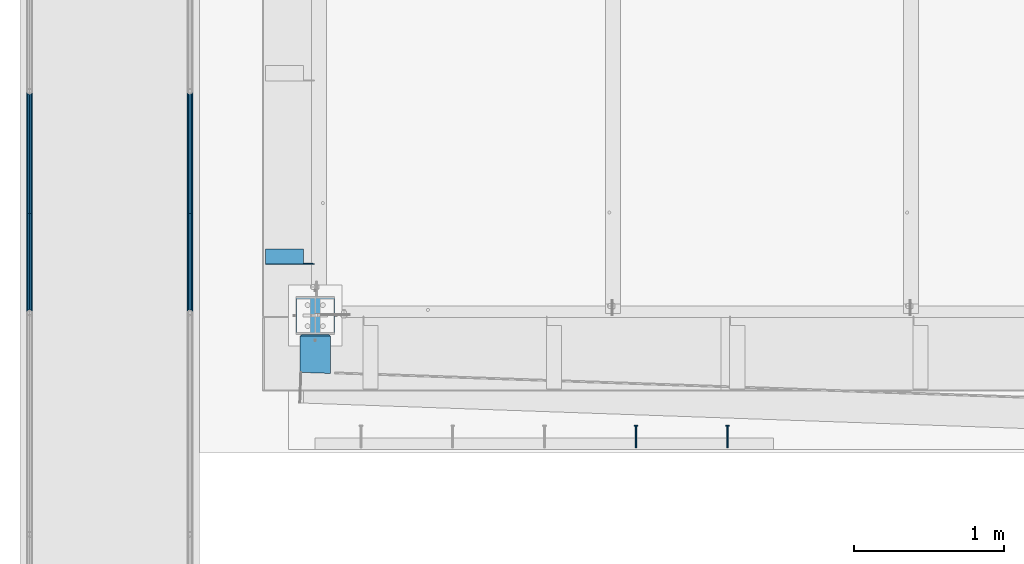
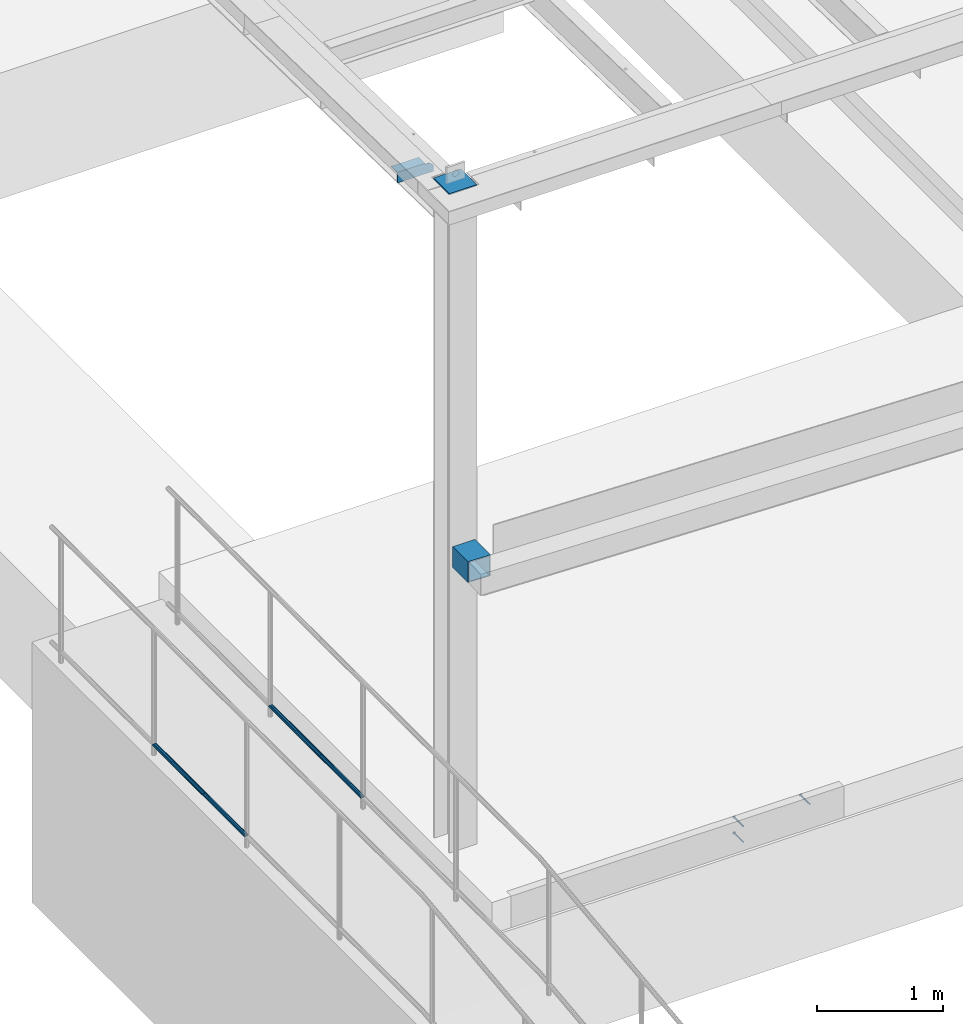
# One storey, part 1184 of 1763: 10 beams, 7 elements without a shape of their own.
"""IFC2X3 building model written with IfcOpenShell, lengths in millimetres."""

from ifc_helpers import new_model, si_unit, frame, origin_with_axes, place, context, subcontext, project, spatial, faceted_brep, material, type_object, element, aggregate, save


model = new_model("IFC2X3")

# Units and contexts
model_context = context("Model", 3, precision=1e-05, world=origin_with_axes())
body_context = subcontext(model_context, "Body", "Model", "MODEL_VIEW")
ifc_project = project(units=[si_unit("LENGTHUNIT", "METRE", prefix="MILLI"), si_unit("AREAUNIT", "SQUARE_METRE"), si_unit("VOLUMEUNIT", "CUBIC_METRE"), si_unit("MASSUNIT", "GRAM", prefix="KILO"), si_unit("TIMEUNIT", "SECOND"), si_unit("PLANEANGLEUNIT", "RADIAN"), si_unit("SOLIDANGLEUNIT", "STERADIAN"), si_unit("THERMODYNAMICTEMPERATUREUNIT", "DEGREE_CELSIUS"), si_unit("LUMINOUSINTENSITYUNIT", "LUMEN")], contexts=[model_context])

# Site, building, storey
site_placement = place(None, origin_with_axes())
site = spatial("IfcSite", under=ifc_project, at=site_placement, CompositionType="ELEMENT")
building_placement = place(site_placement, origin_with_axes())
building = spatial("IfcBuilding", under=site, at=building_placement, Name="Undefined", CompositionType="ELEMENT")
storey_placement = place(building_placement, origin_with_axes())
storey = spatial("IfcBuildingStorey", under=building, at=storey_placement, Name="Undefined", CompositionType="ELEMENT", Elevation=0.0)

# Assembly, beam
assembly_1_placement = place(storey_placement, origin_with_axes())
assembly_1 = element("IfcElementAssembly", 1, at=assembly_1_placement, inside=storey, Name="GUARDRAIL", AssemblyPlace="NOTDEFINED", PredefinedType="RIGID_FRAME")
ifc_material_1 = material(Name="STEEL/A513")
beam_type_1 = type_object("IfcBeamType", PredefinedType="NOTDEFINED")
beam_1_placement = place(assembly_1_placement, frame((-97200.6527017878, 9975.70609643643, 6031.68877066277), z_axis=(0.0, -4.62400000105845e-06, 0.999999999989309), x_axis=(0.0, 0.999999999989309, 4.62400000047487e-06)))
beam_1 = element("IfcBeam", 2, at=beam_1_placement, type_object=beam_type_1, material=ifc_material_1, Name="GUARDRAIL", context=body_context, shape_type="Brep", body=[
    faceted_brep([(796.23942056013, -9.52499999999418, 16.4977839422581), (796.239395102903, -9.52499999999418, 11.4667123801219), (795.745975983124, -7.68349999999919, 13.3082123801214), (793.687198780424, 0.0, 15.3670000001657), (793.687217416407, 0.0, 19.0500000001639), (795.745975983124, 7.68349999999919, 13.3082123801214), (796.239395102903, 9.52499999999418, 11.4667123801219), (796.23942056013, 9.52499999999418, 16.4977839422581), (812.737175030752, 19.0500000000029, 1.72803993336856e-10), (803.21216922002, 16.4977839420899, 9.5250000001688), (803.212072827002, 16.4977839420899, -9.52499999982774), (800.022588339951, 13.3082123799541, 7.68350000016835), (802.08133708151, 15.3669999999984, 1.70075509231538e-10), (800.022510582932, 13.3082123799541, -7.6834999998282), (796.239279059755, 9.52499999999418, -11.4667123797844), (796.239253602527, 9.52499999999418, -16.4977839419216), (795.745841304017, 7.68349999999919, -13.308212379784), (793.687043266358, 0.0, -15.3669999998283), (793.687024630375, 0.0, -19.0499999998274), (796.239279059755, -9.52499999999418, -11.4667123797844), (796.239253602527, -9.52499999999418, -16.4977839419216), (795.745841304017, -7.68349999999919, -13.308212379784), (812.737121023631, -19.0500000000029, 4.44742909166962e-10), (803.212072827002, -16.4977839420899, -9.52499999982774), (803.21216922002, -16.4977839420899, 9.5250000001688), (800.022510582934, -13.3082123799541, -7.6834999998282), (802.081337081512, -15.3669999999984, 1.70075509231538e-10), (800.022588339953, -13.3082123799541, 7.68350000016835), (0.0, -16.4977839420899, -9.52500000000146), (0.0, -9.52499999999418, -16.4977839420935), (1.45519152283669e-11, 1.81898940354586e-12, -19.0499999999993), (0.0, 9.52499999999418, -16.4977839420935), (0.0, 16.4977839420899, -9.52500000000146), (0.0, 19.0500000000029, 0.0), (0.0, 16.4977839420899, 9.52500000000146), (0.0, 9.52499999999418, 16.4977839420935), (1.45519152283669e-11, 1.81898940354586e-12, 19.0499999999993), (0.0, -9.52499999999418, 16.4977839420935), (0.0, -16.4977839420899, 9.52500000000146), (0.0, -19.0500000000029, 0.0), (3.63797880709171e-12, -13.3082123799541, -7.68349999999737), (3.63797880709171e-12, -7.68349999999919, -13.3082123799522), (3.63797880709171e-12, 0.0, -15.3669999999956), (3.63797880709171e-12, 7.68349999999919, -13.3082123799522), (3.63797880709171e-12, 13.3082123799541, -7.68349999999737), (4.71409293822944e-08, 15.3669999999984, 0.0), (-1.81898940354586e-12, 13.3082123799541, 7.68349999999919), (-3.63797880709171e-12, 7.68349999999919, 13.3082123799531), (-1.81898940354586e-12, 0.0, 15.3669999999966), (-3.63797880709171e-12, -7.68349999999919, 13.3082123799531), (-1.81898940354586e-12, -13.3082123799541, 7.68349999999919), (4.71409293822944e-08, -15.3669999999984, 0.0)], [[[0, 1, 2, 3, 4]], [[4, 3, 5, 6, 7]], [[8, 9, 10]], [[7, 6, 11, 12, 13, 14, 15, 10, 9]], [[16, 17, 18, 15, 14]], [[19, 20, 18, 17, 21]], [[22, 23, 24]], [[24, 23, 20, 19, 25, 26, 27, 1, 0]], [[28, 29, 20, 23]], [[29, 30, 18, 20]], [[30, 31, 15, 18]], [[31, 32, 10, 15]], [[32, 33, 8, 10]], [[33, 34, 9, 8]], [[34, 35, 7, 9]], [[35, 36, 4, 7]], [[36, 37, 0, 4]], [[37, 38, 24, 0]], [[38, 39, 22, 24]], [[39, 28, 23, 22]], [[38, 37, 36, 35, 34, 33, 32, 31, 30, 29, 28, 39], [40, 41, 42, 43, 44, 45, 46, 47, 48, 49, 50, 51]], [[40, 51, 26, 25]], [[21, 41, 40, 25, 19]], [[42, 41, 21, 17]], [[43, 42, 17, 16]], [[44, 43, 16, 14, 13]], [[45, 44, 13, 12]], [[46, 45, 12, 11]], [[5, 47, 46, 11, 6]], [[48, 47, 5, 3]], [[49, 48, 3, 2]], [[50, 49, 2, 1, 27]], [[51, 50, 27, 26]]]),
])
aggregate(assembly_1, [beam_1])

assembly_2_placement = place(storey_placement, origin_with_axes())
assembly_2 = element("IfcElementAssembly", 3, at=assembly_2_placement, inside=storey, Name="GUARDRAIL", AssemblyPlace="NOTDEFINED", PredefinedType="RIGID_FRAME")
beam_2_placement = place(assembly_2_placement, frame((-97200.6527017878, 9313.07722717828, 6031.68570659609), z_axis=(0.0, -4.62400000105845e-06, 0.999999999989309), x_axis=(0.0, 0.999999999989309, 4.62400000047487e-06)))
beam_2 = element("IfcBeam", 4, at=beam_2_placement, type_object=beam_type_1, material=ifc_material_1, Name="GUARDRAIL", context=body_context, shape_type="Brep", body=[
    faceted_brep([(2.16604427796847, 19.0500000000029, 0.0), (11.6909420741176, 16.4977839420899, -9.52499999999509), (11.6910384671355, 16.4977839420899, 9.52499999999964), (11.6910384671355, -16.4977839420899, 9.52499999999964), (11.6909420741176, -16.4977839420899, -9.52499999999509), (2.16604427796847, -19.0500000000029, 0.0), (18.6638576916084, -9.52499999999418, 16.4977839420944), (18.6638322343806, -9.52499999999418, 11.4667123799572), (14.8806007114235, -13.3082123799541, 7.68350000000191), (12.8217742128418, -15.3669999999984, 2.72848410531878e-12), (14.8805229544032, -13.3082123799541, -7.68349999999464), (18.6637161912331, -9.52499999999418, -11.4667123799491), (18.6636907340053, -9.52499999999418, -16.4977839420862), (21.2159125137114, 0.0, -15.3669999999929), (21.2158938777284, 0.0, -19.0499999999911), (19.1571353112286, -7.68349999999919, -13.3082123799486), (19.1571353112286, 7.68349999999919, -13.3082123799486), (18.6637161912331, 9.52499999999418, -11.4667123799491), (18.6636907340053, 9.52499999999418, -16.4977839420862), (14.8805229544014, 13.3082123799541, -7.68349999999464), (12.82177421284, 15.3669999999984, 2.72848410531878e-12), (14.8806007114217, 13.3082123799541, 7.68350000000191), (18.6638322343806, 9.52499999999418, 11.4667123799572), (18.6638576916084, 9.52499999999418, 16.4977839420944), (19.1572699903372, 7.68349999999919, 13.3082123799568), (21.2160680277793, 0.0, 15.3670000000011), (21.2160866637623, 0.0, 19.0500000000002), (19.1572699903372, -7.68349999999919, 13.3082123799568), (662.628869265089, -19.0500000000029, 1.40971678774804e-10), (662.628869265085, -16.4977839420899, 9.52500000013879), (662.628869265085, -9.52499999999418, 16.4977839422299), (662.628869265083, 0.0, 19.0500000001357), (662.628869265092, -9.52499999999418, -16.4977839419489), (662.628869265091, -16.4977839420899, -9.52499999985685), (662.628869265092, 0.0, -19.0499999998556), (662.628869265092, 9.52499999999418, -16.4977839419489), (662.628869265091, 16.4977839420899, -9.52499999985685), (662.628869265089, 19.0500000000029, 1.40971678774804e-10), (662.628869265085, 16.4977839420899, 9.52500000013879), (662.628869265085, 9.52499999999418, 16.4977839422299), (662.628869265085, -7.68349999999919, 13.3082123800932), (662.628869265085, 0.0, 15.3670000001375), (662.628869265085, 7.68349999999919, 13.3082123800923), (662.628869265087, 13.3082123799541, 7.68350000013834), (662.628869265089, 15.3669999999984, 1.40971678774804e-10), (662.628869265089, 13.3082123799541, -7.6834999998573), (662.628869265091, 7.68349999999919, -13.3082123798113), (662.628869265092, 0.0, -15.3669999998565), (662.628869265091, -7.68349999999919, -13.3082123798113), (662.628869265089, -13.3082123799541, -7.6834999998573), (662.628869265089, -15.3669999999984, 1.40971678774804e-10), (662.628869265087, -13.3082123799541, 7.68350000013834)], [[[0, 1, 2]], [[3, 4, 5]], [[6, 7, 8, 9, 10, 11, 12, 4, 3]], [[13, 14, 12, 11, 15]], [[16, 17, 18, 14, 13]], [[2, 1, 18, 17, 19, 20, 21, 22, 23]], [[23, 22, 24, 25, 26]], [[26, 25, 27, 7, 6]], [[28, 29, 3, 5]], [[29, 30, 6, 3]], [[30, 31, 26, 6]], [[32, 33, 4, 12]], [[34, 32, 12, 14]], [[35, 34, 14, 18]], [[36, 35, 18, 1]], [[37, 36, 1, 0]], [[38, 37, 0, 2]], [[39, 38, 2, 23]], [[31, 39, 23, 26]], [[33, 28, 5, 4]], [[32, 34, 35, 36, 37, 38, 39, 31, 30, 29, 28, 33], [40, 41, 42, 43, 44, 45, 46, 47, 48, 49, 50, 51]], [[42, 41, 25, 24]], [[21, 43, 42, 24, 22]], [[44, 43, 21, 20]], [[45, 44, 20, 19]], [[46, 45, 19, 17, 16]], [[47, 46, 16, 13]], [[48, 47, 13, 15]], [[10, 49, 48, 15, 11]], [[50, 49, 10, 9]], [[51, 50, 9, 8]], [[40, 51, 8, 7, 27]], [[41, 40, 27, 25]]]),
])
aggregate(assembly_2, [beam_2])

assembly_3_placement = place(storey_placement, origin_with_axes())
assembly_3 = element("IfcElementAssembly", 5, at=assembly_3_placement, inside=storey, Name="GUARDRAIL", AssemblyPlace="NOTDEFINED", PredefinedType="RIGID_FRAME")
beam_3_placement = place(assembly_3_placement, frame((-96133.8527017878, 9975.70609643643, 6031.68877066277), z_axis=(0.0, -4.62400000105845e-06, 0.999999999989309), x_axis=(0.0, 0.999999999989309, 4.62400000047487e-06)))
beam_3 = element("IfcBeam", 6, at=beam_3_placement, type_object=beam_type_1, material=ifc_material_1, Name="GUARDRAIL", context=body_context, shape_type="Brep", body=[
    faceted_brep([(796.23942056013, -9.52499999999418, 16.4977839422581), (796.239395102903, -9.52499999999418, 11.4667123801219), (795.745975983124, -7.68349999999919, 13.3082123801214), (793.687198780424, 0.0, 15.3670000001657), (793.687217416407, 0.0, 19.0500000001639), (795.745975983124, 7.68349999999919, 13.3082123801214), (796.239395102903, 9.52499999999418, 11.4667123801219), (796.23942056013, 9.52499999999418, 16.4977839422581), (812.737175030752, 19.0500000000029, 1.72803993336856e-10), (803.21216922002, 16.4977839420899, 9.5250000001688), (803.212072827002, 16.4977839420899, -9.52499999982774), (800.022588339951, 13.3082123799541, 7.68350000016835), (802.08133708151, 15.3669999999984, 1.70075509231538e-10), (800.022510582932, 13.3082123799541, -7.6834999998282), (796.239279059755, 9.52499999999418, -11.4667123797844), (796.239253602527, 9.52499999999418, -16.4977839419216), (795.745841304017, 7.68349999999919, -13.308212379784), (793.687043266358, 0.0, -15.3669999998283), (793.687024630375, 0.0, -19.0499999998274), (796.239279059755, -9.52499999999418, -11.4667123797844), (796.239253602527, -9.52499999999418, -16.4977839419216), (795.745841304017, -7.68349999999919, -13.308212379784), (812.737121023631, -19.0500000000029, 4.44742909166962e-10), (803.212072827002, -16.4977839420899, -9.52499999982774), (803.21216922002, -16.4977839420899, 9.5250000001688), (800.022510582934, -13.3082123799541, -7.6834999998282), (802.081337081512, -15.3669999999984, 1.70075509231538e-10), (800.022588339953, -13.3082123799541, 7.68350000016835), (0.0, -16.4977839420899, -9.52500000000146), (0.0, -9.52499999999418, -16.4977839420935), (1.45519152283669e-11, 1.81898940354586e-12, -19.0499999999993), (0.0, 9.52499999999418, -16.4977839420935), (0.0, 16.4977839420899, -9.52500000000146), (0.0, 19.0500000000029, 0.0), (0.0, 16.4977839420899, 9.52500000000146), (0.0, 9.52499999999418, 16.4977839420935), (1.45519152283669e-11, 1.81898940354586e-12, 19.0499999999993), (0.0, -9.52499999999418, 16.4977839420935), (0.0, -16.4977839420899, 9.52500000000146), (0.0, -19.0500000000029, 0.0), (3.63797880709171e-12, -13.3082123799541, -7.68349999999737), (3.63797880709171e-12, -7.68349999999919, -13.3082123799522), (3.63797880709171e-12, 0.0, -15.3669999999956), (3.63797880709171e-12, 7.68349999999919, -13.3082123799522), (3.63797880709171e-12, 13.3082123799541, -7.68349999999737), (4.71409293822944e-08, 15.3669999999984, 0.0), (-1.81898940354586e-12, 13.3082123799541, 7.68349999999919), (-3.63797880709171e-12, 7.68349999999919, 13.3082123799531), (-1.81898940354586e-12, 0.0, 15.3669999999966), (-3.63797880709171e-12, -7.68349999999919, 13.3082123799531), (-1.81898940354586e-12, -13.3082123799541, 7.68349999999919), (4.71409293822944e-08, -15.3669999999984, 0.0)], [[[0, 1, 2, 3, 4]], [[4, 3, 5, 6, 7]], [[8, 9, 10]], [[7, 6, 11, 12, 13, 14, 15, 10, 9]], [[16, 17, 18, 15, 14]], [[19, 20, 18, 17, 21]], [[22, 23, 24]], [[24, 23, 20, 19, 25, 26, 27, 1, 0]], [[28, 29, 20, 23]], [[29, 30, 18, 20]], [[30, 31, 15, 18]], [[31, 32, 10, 15]], [[32, 33, 8, 10]], [[33, 34, 9, 8]], [[34, 35, 7, 9]], [[35, 36, 4, 7]], [[36, 37, 0, 4]], [[37, 38, 24, 0]], [[38, 39, 22, 24]], [[39, 28, 23, 22]], [[38, 37, 36, 35, 34, 33, 32, 31, 30, 29, 28, 39], [40, 41, 42, 43, 44, 45, 46, 47, 48, 49, 50, 51]], [[40, 51, 26, 25]], [[21, 41, 40, 25, 19]], [[42, 41, 21, 17]], [[43, 42, 17, 16]], [[44, 43, 16, 14, 13]], [[45, 44, 13, 12]], [[46, 45, 12, 11]], [[5, 47, 46, 11, 6]], [[48, 47, 5, 3]], [[49, 48, 3, 2]], [[50, 49, 2, 1, 27]], [[51, 50, 27, 26]]]),
])
aggregate(assembly_3, [beam_3])

assembly_4_placement = place(storey_placement, origin_with_axes())
assembly_4 = element("IfcElementAssembly", 7, at=assembly_4_placement, inside=storey, Name="GUARDRAIL", AssemblyPlace="NOTDEFINED", PredefinedType="RIGID_FRAME")
beam_4_placement = place(assembly_4_placement, frame((-96133.8527017878, 9313.07722717828, 6031.68570659609), z_axis=(0.0, -4.62400000105845e-06, 0.999999999989309), x_axis=(0.0, 0.999999999989309, 4.62400000047487e-06)))
beam_4 = element("IfcBeam", 8, at=beam_4_placement, type_object=beam_type_1, material=ifc_material_1, Name="GUARDRAIL", context=body_context, shape_type="Brep", body=[
    faceted_brep([(2.16604427796847, 19.0500000000029, 0.0), (11.6909420741176, 16.4977839420899, -9.52499999999509), (11.6910384671355, 16.4977839420899, 9.52499999999964), (11.6910384671355, -16.4977839420899, 9.52499999999964), (11.6909420741176, -16.4977839420899, -9.52499999999509), (2.16604427796847, -19.0500000000029, 0.0), (18.6638576916084, -9.52499999999418, 16.4977839420944), (18.6638322343806, -9.52499999999418, 11.4667123799572), (14.8806007114235, -13.3082123799541, 7.68350000000191), (12.8217742128418, -15.3669999999984, 2.72848410531878e-12), (14.8805229544032, -13.3082123799541, -7.68349999999464), (18.6637161912331, -9.52499999999418, -11.4667123799491), (18.6636907340053, -9.52499999999418, -16.4977839420862), (21.2159125137114, 0.0, -15.3669999999929), (21.2158938777284, 0.0, -19.0499999999911), (19.1571353112286, -7.68349999999919, -13.3082123799486), (19.1571353112286, 7.68349999999919, -13.3082123799486), (18.6637161912331, 9.52499999999418, -11.4667123799491), (18.6636907340053, 9.52499999999418, -16.4977839420862), (14.8805229544014, 13.3082123799541, -7.68349999999464), (12.82177421284, 15.3669999999984, 2.72848410531878e-12), (14.8806007114217, 13.3082123799541, 7.68350000000191), (18.6638322343806, 9.52499999999418, 11.4667123799572), (18.6638576916084, 9.52499999999418, 16.4977839420944), (19.1572699903372, 7.68349999999919, 13.3082123799568), (21.2160680277793, 0.0, 15.3670000000011), (21.2160866637623, 0.0, 19.0500000000002), (19.1572699903372, -7.68349999999919, 13.3082123799568), (662.628869265089, -19.0500000000029, 1.40971678774804e-10), (662.628869265085, -16.4977839420899, 9.52500000013879), (662.628869265085, -9.52499999999418, 16.4977839422299), (662.628869265083, 0.0, 19.0500000001357), (662.628869265092, -9.52499999999418, -16.4977839419489), (662.628869265091, -16.4977839420899, -9.52499999985685), (662.628869265092, 0.0, -19.0499999998556), (662.628869265092, 9.52499999999418, -16.4977839419489), (662.628869265091, 16.4977839420899, -9.52499999985685), (662.628869265089, 19.0500000000029, 1.40971678774804e-10), (662.628869265085, 16.4977839420899, 9.52500000013879), (662.628869265085, 9.52499999999418, 16.4977839422299), (662.628869265085, -7.68349999999919, 13.3082123800932), (662.628869265085, 0.0, 15.3670000001375), (662.628869265085, 7.68349999999919, 13.3082123800923), (662.628869265087, 13.3082123799541, 7.68350000013834), (662.628869265089, 15.3669999999984, 1.40971678774804e-10), (662.628869265089, 13.3082123799541, -7.6834999998573), (662.628869265091, 7.68349999999919, -13.3082123798113), (662.628869265092, 0.0, -15.3669999998565), (662.628869265091, -7.68349999999919, -13.3082123798113), (662.628869265089, -13.3082123799541, -7.6834999998573), (662.628869265089, -15.3669999999984, 1.40971678774804e-10), (662.628869265087, -13.3082123799541, 7.68350000013834)], [[[0, 1, 2]], [[3, 4, 5]], [[6, 7, 8, 9, 10, 11, 12, 4, 3]], [[13, 14, 12, 11, 15]], [[16, 17, 18, 14, 13]], [[2, 1, 18, 17, 19, 20, 21, 22, 23]], [[23, 22, 24, 25, 26]], [[26, 25, 27, 7, 6]], [[28, 29, 3, 5]], [[29, 30, 6, 3]], [[30, 31, 26, 6]], [[32, 33, 4, 12]], [[34, 32, 12, 14]], [[35, 34, 14, 18]], [[36, 35, 18, 1]], [[37, 36, 1, 0]], [[38, 37, 0, 2]], [[39, 38, 2, 23]], [[31, 39, 23, 26]], [[33, 28, 5, 4]], [[32, 34, 35, 36, 37, 38, 39, 31, 30, 29, 28, 33], [40, 41, 42, 43, 44, 45, 46, 47, 48, 49, 50, 51]], [[42, 41, 25, 24]], [[21, 43, 42, 24, 22]], [[44, 43, 21, 20]], [[45, 44, 20, 19]], [[46, 45, 19, 17, 16]], [[47, 46, 16, 13]], [[48, 47, 13, 15]], [[10, 49, 48, 15, 11]], [[50, 49, 10, 9]], [[51, 50, 9, 8]], [[40, 51, 8, 7, 27]], [[41, 40, 27, 25]]]),
])
aggregate(assembly_4, [beam_4])

# Assembly, beams
assembly_5_placement = place(storey_placement, origin_with_axes())
assembly_5 = element("IfcElementAssembly", 9, at=assembly_5_placement, inside=storey, Name="EMBED", AssemblyPlace="NOTDEFINED", PredefinedType="RIGID_FRAME")
ifc_material_2 = material(Name="STEEL/A36")
beam_type_2 = type_object("IfcBeamType", PredefinedType="NOTDEFINED")
beam_5_placement = place(assembly_5_placement, frame((-92557.0372736984, 8415.3373046875, 5257.8), z_axis=(0.0, 0.0, 1.0), x_axis=(0.0, 1.0, 0.0)))
beam_5 = element("IfcBeam", 10, at=beam_5_placement, type_object=beam_type_2, material=ifc_material_2, Name="HEADED STUD ANCHOR", context=body_context, shape_type="Brep", body=[
    faceted_brep([(0.0, -3.1800000667572, 5.5), (0.0, -5.5, 3.1800000667572), (141.732000000002, -5.5, 3.1800000667572), (141.732000000002, -3.1800000667572, 5.5), (0.0, -6.34999999999491, 1.45519152283669e-11), (141.732000000002, -6.34999990463257, 0.0), (0.0, -5.5, -3.1800000667572), (141.732000000002, -5.5, -3.1800000667572), (0.0, -3.1800000667572, -5.5), (141.732000000002, -3.1800000667572, -5.5), (0.0, 0.0, -6.34999990463257), (141.732000000002, 0.0, -6.34999990463257), (0.0, 3.1800000667572, -5.5), (141.732000000002, 3.1800000667572, -5.5), (0.0, 5.5, -3.1800000667572), (141.732000000002, 5.5, -3.1800000667572), (0.0, 6.34999999999491, -2.91038304567337e-11), (141.732000000002, 6.34999990463257, 0.0), (0.0, 5.5, 3.1800000667572), (141.732000000002, 5.5, 3.1800000667572), (0.0, 3.1800000667572, 5.5), (141.732000000002, 3.1800000667572, 5.5), (0.0, 0.0, 6.34999990463257), (141.732000000002, 0.0, 6.34999990463257), (144.780000000001, -10.9899997711182, 6.34999990463257), (144.780000000001, -6.34000015258789, 10.9899997711182), (144.780000000001, -12.6999998092651, 0.0), (144.780000000001, -10.9899997711182, -6.34999990463257), (144.780000000001, -6.34000015258789, -10.9899997711182), (144.780000000001, 0.0, -12.6899995803833), (144.780000000001, 6.34000015258789, -10.9899997711182), (144.780000000001, 10.9899997711182, -6.34999990463257), (144.780000000001, 12.6999998092651, 0.0), (144.780000000001, 10.9899997711182, 6.34999990463257), (144.780000000001, 6.34000015258789, 10.9899997711182), (144.780000000001, 0.0, 12.6899995803833), (152.400000000001, -10.9899997711182, 6.34999990463257), (152.400000000001, -6.34000015258789, 10.9899997711182), (152.400000000001, -12.6999998092651, 0.0), (152.400000000001, -10.9899997711182, -6.34999990463257), (152.400000000001, -6.34000015258789, -10.9899997711182), (152.400000000001, 0.0, -12.6899995803833), (152.400000000001, 6.34000015258789, -10.9899997711182), (152.400000000001, 10.9899997711182, -6.34999990463257), (152.400000000001, 12.6999998092651, 0.0), (152.400000000001, 10.9899997711182, 6.34999990463257), (152.400000000001, 6.34000015258789, 10.9899997711182), (152.400000000001, 0.0, 12.6899995803833)], [[[0, 1, 2, 3]], [[1, 4, 5, 2]], [[4, 6, 7, 5]], [[6, 8, 9, 7]], [[8, 10, 11, 9]], [[10, 12, 13, 11]], [[12, 14, 15, 13]], [[14, 16, 17, 15]], [[16, 18, 19, 17]], [[18, 20, 21, 19]], [[20, 22, 23, 21]], [[22, 0, 3, 23]], [[22, 20, 18, 16, 14, 12, 10, 8, 6, 4, 1, 0]], [[3, 2, 24, 25]], [[2, 5, 26, 24]], [[5, 7, 27, 26]], [[7, 9, 28, 27]], [[9, 11, 29, 28]], [[11, 13, 30, 29]], [[13, 15, 31, 30]], [[15, 17, 32, 31]], [[17, 19, 33, 32]], [[19, 21, 34, 33]], [[21, 23, 35, 34]], [[23, 3, 25, 35]], [[25, 24, 36, 37]], [[24, 26, 38, 36]], [[26, 27, 39, 38]], [[27, 28, 40, 39]], [[28, 29, 41, 40]], [[29, 30, 42, 41]], [[30, 31, 43, 42]], [[31, 32, 44, 43]], [[32, 33, 45, 44]], [[33, 34, 46, 45]], [[34, 35, 47, 46]], [[35, 25, 37, 47]], [[38, 39, 40, 41, 42, 43, 44, 45, 46, 47, 37, 36]]]),
])
beam_6_placement = place(assembly_5_placement, frame((-93166.6372736984, 8415.3373046875, 5105.4), z_axis=(0.0, 0.0, 1.0), x_axis=(0.0, 1.0, 0.0)))
beam_6 = element("IfcBeam", 11, at=beam_6_placement, type_object=beam_type_2, material=ifc_material_2, Name="HEADED STUD ANCHOR", context=body_context, shape_type="Brep", body=[
    faceted_brep([(0.0, -3.1800000667572, 5.5), (0.0, -5.5, 3.1800000667572), (141.732000000002, -5.5, 3.1800000667572), (141.732000000002, -3.1800000667572, 5.5), (0.0, -6.34999999999491, 1.45519152283669e-11), (141.732000000002, -6.34999990463257, 0.0), (0.0, -5.5, -3.1800000667572), (141.732000000002, -5.5, -3.1800000667572), (0.0, -3.1800000667572, -5.5), (141.732000000002, -3.1800000667572, -5.5), (0.0, 0.0, -6.34999990463257), (141.732000000002, 0.0, -6.34999990463257), (0.0, 3.1800000667572, -5.5), (141.732000000002, 3.1800000667572, -5.5), (0.0, 5.5, -3.1800000667572), (141.732000000002, 5.5, -3.1800000667572), (0.0, 6.34999999999491, -2.91038304567337e-11), (141.732000000002, 6.34999990463257, 0.0), (0.0, 5.5, 3.1800000667572), (141.732000000002, 5.5, 3.1800000667572), (0.0, 3.1800000667572, 5.5), (141.732000000002, 3.1800000667572, 5.5), (0.0, 0.0, 6.34999990463257), (141.732000000002, 0.0, 6.34999990463257), (144.780000000001, -10.9899997711182, 6.34999990463257), (144.780000000001, -6.34000015258789, 10.9899997711182), (144.780000000001, -12.6999998092651, 0.0), (144.780000000001, -10.9899997711182, -6.34999990463257), (144.780000000001, -6.34000015258789, -10.9899997711182), (144.780000000001, 0.0, -12.6899995803833), (144.780000000001, 6.34000015258789, -10.9899997711182), (144.780000000001, 10.9899997711182, -6.34999990463257), (144.780000000001, 12.6999998092651, 0.0), (144.780000000001, 10.9899997711182, 6.34999990463257), (144.780000000001, 6.34000015258789, 10.9899997711182), (144.780000000001, 0.0, 12.6899995803833), (152.400000000001, -10.9899997711182, 6.34999990463257), (152.400000000001, -6.34000015258789, 10.9899997711182), (152.400000000001, -12.6999998092651, 0.0), (152.400000000001, -10.9899997711182, -6.34999990463257), (152.400000000001, -6.34000015258789, -10.9899997711182), (152.400000000001, 0.0, -12.6899995803833), (152.400000000001, 6.34000015258789, -10.9899997711182), (152.400000000001, 10.9899997711182, -6.34999990463257), (152.400000000001, 12.6999998092651, 0.0), (152.400000000001, 10.9899997711182, 6.34999990463257), (152.400000000001, 6.34000015258789, 10.9899997711182), (152.400000000001, 0.0, 12.6899995803833)], [[[0, 1, 2, 3]], [[1, 4, 5, 2]], [[4, 6, 7, 5]], [[6, 8, 9, 7]], [[8, 10, 11, 9]], [[10, 12, 13, 11]], [[12, 14, 15, 13]], [[14, 16, 17, 15]], [[16, 18, 19, 17]], [[18, 20, 21, 19]], [[20, 22, 23, 21]], [[22, 0, 3, 23]], [[22, 20, 18, 16, 14, 12, 10, 8, 6, 4, 1, 0]], [[3, 2, 24, 25]], [[2, 5, 26, 24]], [[5, 7, 27, 26]], [[7, 9, 28, 27]], [[9, 11, 29, 28]], [[11, 13, 30, 29]], [[13, 15, 31, 30]], [[15, 17, 32, 31]], [[17, 19, 33, 32]], [[19, 21, 34, 33]], [[21, 23, 35, 34]], [[23, 3, 25, 35]], [[25, 24, 36, 37]], [[24, 26, 38, 36]], [[26, 27, 39, 38]], [[27, 28, 40, 39]], [[28, 29, 41, 40]], [[29, 30, 42, 41]], [[30, 31, 43, 42]], [[31, 32, 44, 43]], [[32, 33, 45, 44]], [[33, 34, 46, 45]], [[34, 35, 47, 46]], [[35, 25, 37, 47]], [[38, 39, 40, 41, 42, 43, 44, 45, 46, 47, 37, 36]]]),
])
beam_7_placement = place(assembly_5_placement, frame((-93166.6372736984, 8415.3373046875, 5257.8), z_axis=(0.0, 0.0, 1.0), x_axis=(0.0, 1.0, 0.0)))
beam_7 = element("IfcBeam", 12, at=beam_7_placement, type_object=beam_type_2, material=ifc_material_2, Name="HEADED STUD ANCHOR", context=body_context, shape_type="Brep", body=[
    faceted_brep([(0.0, -3.1800000667572, 5.5), (0.0, -5.5, 3.1800000667572), (141.732000000002, -5.5, 3.1800000667572), (141.732000000002, -3.1800000667572, 5.5), (0.0, -6.34999999999491, 1.45519152283669e-11), (141.732000000002, -6.34999990463257, 0.0), (0.0, -5.5, -3.1800000667572), (141.732000000002, -5.5, -3.1800000667572), (0.0, -3.1800000667572, -5.5), (141.732000000002, -3.1800000667572, -5.5), (0.0, 0.0, -6.34999990463257), (141.732000000002, 0.0, -6.34999990463257), (0.0, 3.1800000667572, -5.5), (141.732000000002, 3.1800000667572, -5.5), (0.0, 5.5, -3.1800000667572), (141.732000000002, 5.5, -3.1800000667572), (0.0, 6.34999999999491, -2.91038304567337e-11), (141.732000000002, 6.34999990463257, 0.0), (0.0, 5.5, 3.1800000667572), (141.732000000002, 5.5, 3.1800000667572), (0.0, 3.1800000667572, 5.5), (141.732000000002, 3.1800000667572, 5.5), (0.0, 0.0, 6.34999990463257), (141.732000000002, 0.0, 6.34999990463257), (144.780000000001, -10.9899997711182, 6.34999990463257), (144.780000000001, -6.34000015258789, 10.9899997711182), (144.780000000001, -12.6999998092651, 0.0), (144.780000000001, -10.9899997711182, -6.34999990463257), (144.780000000001, -6.34000015258789, -10.9899997711182), (144.780000000001, 0.0, -12.6899995803833), (144.780000000001, 6.34000015258789, -10.9899997711182), (144.780000000001, 10.9899997711182, -6.34999990463257), (144.780000000001, 12.6999998092651, 0.0), (144.780000000001, 10.9899997711182, 6.34999990463257), (144.780000000001, 6.34000015258789, 10.9899997711182), (144.780000000001, 0.0, 12.6899995803833), (152.400000000001, -10.9899997711182, 6.34999990463257), (152.400000000001, -6.34000015258789, 10.9899997711182), (152.400000000001, -12.6999998092651, 0.0), (152.400000000001, -10.9899997711182, -6.34999990463257), (152.400000000001, -6.34000015258789, -10.9899997711182), (152.400000000001, 0.0, -12.6899995803833), (152.400000000001, 6.34000015258789, -10.9899997711182), (152.400000000001, 10.9899997711182, -6.34999990463257), (152.400000000001, 12.6999998092651, 0.0), (152.400000000001, 10.9899997711182, 6.34999990463257), (152.400000000001, 6.34000015258789, 10.9899997711182), (152.400000000001, 0.0, 12.6899995803833)], [[[0, 1, 2, 3]], [[1, 4, 5, 2]], [[4, 6, 7, 5]], [[6, 8, 9, 7]], [[8, 10, 11, 9]], [[10, 12, 13, 11]], [[12, 14, 15, 13]], [[14, 16, 17, 15]], [[16, 18, 19, 17]], [[18, 20, 21, 19]], [[20, 22, 23, 21]], [[22, 0, 3, 23]], [[22, 20, 18, 16, 14, 12, 10, 8, 6, 4, 1, 0]], [[3, 2, 24, 25]], [[2, 5, 26, 24]], [[5, 7, 27, 26]], [[7, 9, 28, 27]], [[9, 11, 29, 28]], [[11, 13, 30, 29]], [[13, 15, 31, 30]], [[15, 17, 32, 31]], [[17, 19, 33, 32]], [[19, 21, 34, 33]], [[21, 23, 35, 34]], [[23, 3, 25, 35]], [[25, 24, 36, 37]], [[24, 26, 38, 36]], [[26, 27, 39, 38]], [[27, 28, 40, 39]], [[28, 29, 41, 40]], [[29, 30, 42, 41]], [[30, 31, 43, 42]], [[31, 32, 44, 43]], [[32, 33, 45, 44]], [[33, 34, 46, 45]], [[34, 35, 47, 46]], [[35, 25, 37, 47]], [[38, 39, 40, 41, 42, 43, 44, 45, 46, 47, 37, 36]]]),
])
aggregate(assembly_5, [beam_5, beam_6, beam_7])

# Assembly, beam
assembly_6_placement = place(storey_placement, origin_with_axes())
assembly_6 = element("IfcElementAssembly", 13, at=assembly_6_placement, inside=storey, Name="COLUMN", AssemblyPlace="NOTDEFINED", PredefinedType="RIGID_FRAME")
ifc_material_3 = material()
beam_type_3 = type_object("IfcBeamType", Name="HSS8X8X3/8", PredefinedType="NOTDEFINED")
beam_8_placement = place(assembly_6_placement, frame((-95300.2372736984, 8712.20000000001, 8197.85), z_axis=(0.0, 0.0, 1.0), x_axis=(0.0, 1.0, 0.0)))
beam_8 = element("IfcBeam", 14, at=beam_8_placement, type_object=beam_type_3, material=ifc_material_3, Name="BEAM", ObjectType="HSS8X8X3/8", context=body_context, shape_type="Brep", body=[
    faceted_brep([(457.199999999977, 92.0749999999971, 92.0750000000007), (457.199999999977, 92.0749999999971, -92.0749999999998), (447.674999999977, 101.600000000006, -101.6), (447.674999999977, 101.600000000006, 101.6), (457.199999999977, -92.0749999999971, -92.0749999999998), (447.674999999977, -101.600000000006, -101.6), (457.199999999977, -92.0749999999971, 92.0750000000007), (447.674999999977, -101.600000000006, 101.6), (206.509359585274, 92.0749999999971, 92.0750000000007), (206.509359585274, 92.0749999999971, -92.0749999999998), (200.016891556235, -92.0749999999971, 92.0750000000007), (200.016891556235, -92.0749999999971, -92.0749999999998), (199.681074244389, -101.600000000006, -101.6), (199.681074244389, -101.600000000006, 101.6), (206.845176897121, 101.600000000006, 101.6), (206.845176897121, 101.600000000006, -101.6)], [[[0, 1, 2, 3]], [[4, 5, 2, 1]], [[6, 7, 5, 4]], [[8, 9, 1, 0]], [[10, 8, 0, 6]], [[11, 10, 6, 4]], [[9, 11, 4, 1]], [[12, 13, 14, 15], [8, 10, 11, 9]], [[15, 14, 3, 2]], [[12, 15, 2, 5]], [[13, 12, 5, 7]], [[14, 13, 7, 3]], [[0, 3, 7, 6]]]),
])

assembly_7_placement = place(storey_placement, origin_with_axes())
assembly_7 = element("IfcElementAssembly", 15, at=assembly_7_placement, inside=storey, Name="BEAM", AssemblyPlace="NOTDEFINED", PredefinedType="RIGID_FRAME")
beam_type_4 = type_object("IfcBeamType", Name="L4X4X1/4", PredefinedType="NOTDEFINED")
beam_9_placement = place(assembly_7_placement, frame((-95631.230978276, 9689.03745418481, 11663.4015180068), z_axis=(0.0, -0.0198756880000401, -0.99980245900204), x_axis=(1.0, 0.0, 0.0)))
beam_9 = element("IfcBeam", 16, at=beam_9_placement, type_object=beam_type_4, material=ifc_material_2, Name="BRACE", ObjectType="L4X4X1/4", context=body_context, shape_type="Brep", body=[
    faceted_brep([(327.025004577677, 44.4499999999935, -7.93687452423728), (295.275004577677, 44.4499999999389, -39.6874998085623), (295.275004577677, 50.7999999999374, -39.6874998085495), (327.025004577648, 50.799999999992, -7.93687452422455), (1.96450855582952e-10, -50.8000000000338, -44.4499999999534), (2.11002770811319e-10, -50.8000000000357, -50.799999999952), (253.206254577657, -50.8000000000975, -50.8000000000193), (253.206254577657, -50.8000000000902, -44.4500000000171), (-3.63797880709171e-11, 50.8000000000011, -50.8000000000538), (253.206254577657, 50.7999999999229, -50.8000000000084), (253.206254577657, 44.4499999999316, -44.450000000008), (253.206254577657, 50.7999999999374, -39.6874998085495), (253.206254577657, 44.4499999999389, -39.6874998085623), (-2.18278728425503e-11, 44.4500000000007, -44.450000000048), (-1.81898940354586e-10, 44.4500000000371, 50.7999999999374), (-1.96450855582952e-10, 50.8000000000393, 50.7999999999374), (327.025004577648, 44.4500000000953, 50.8000000000138), (327.025004577648, 50.8000000000939, 50.800000000012)], [[[0, 1, 2, 3]], [[4, 5, 6, 7]], [[5, 8, 9, 6]], [[10, 7, 6, 9, 11, 12]], [[13, 4, 7, 10]], [[5, 4, 13, 14, 15, 8]], [[15, 14, 16, 17]], [[17, 16, 0, 3]], [[11, 9, 8, 15, 17, 3, 2]], [[12, 11, 2, 1]], [[16, 14, 13, 10, 12, 1, 0]]]),
])
aggregate(assembly_7, [beam_9])

# Beam
beam_type_5 = type_object("IfcBeamType", PredefinedType="NOTDEFINED")
beam_10_placement = place(assembly_6_placement, frame((-95300.2372736984, 9169.40000000001, 11715.6670365097), z_axis=(1.0, 0.0, 0.0), x_axis=(0.0, 1.0, 0.0)))
beam_10 = element("IfcBeam", 17, at=beam_10_placement, type_object=beam_type_5, material=ifc_material_2, Name="PLATE", context=body_context, shape_type="Brep", body=[
    faceted_brep([(0.0, 6.35000000000036, -127.0), (0.0, 6.35000000000036, 127.0), (254.0, 6.35000000000036, 127.0), (254.0, 6.35000000000036, -127.0), (0.0, -6.35000000000036, 127.0), (254.0, -6.35000000000036, 127.0), (0.0, -6.35000000000036, -127.0), (254.0, -6.35000000000036, -127.0)], [[[0, 1, 2, 3]], [[1, 4, 5, 2]], [[4, 6, 7, 5]], [[6, 0, 3, 7]], [[5, 7, 3, 2]], [[6, 4, 1, 0]]]),
])

aggregate(assembly_6, [beam_8, beam_10])

save(model, "model.ifc")
